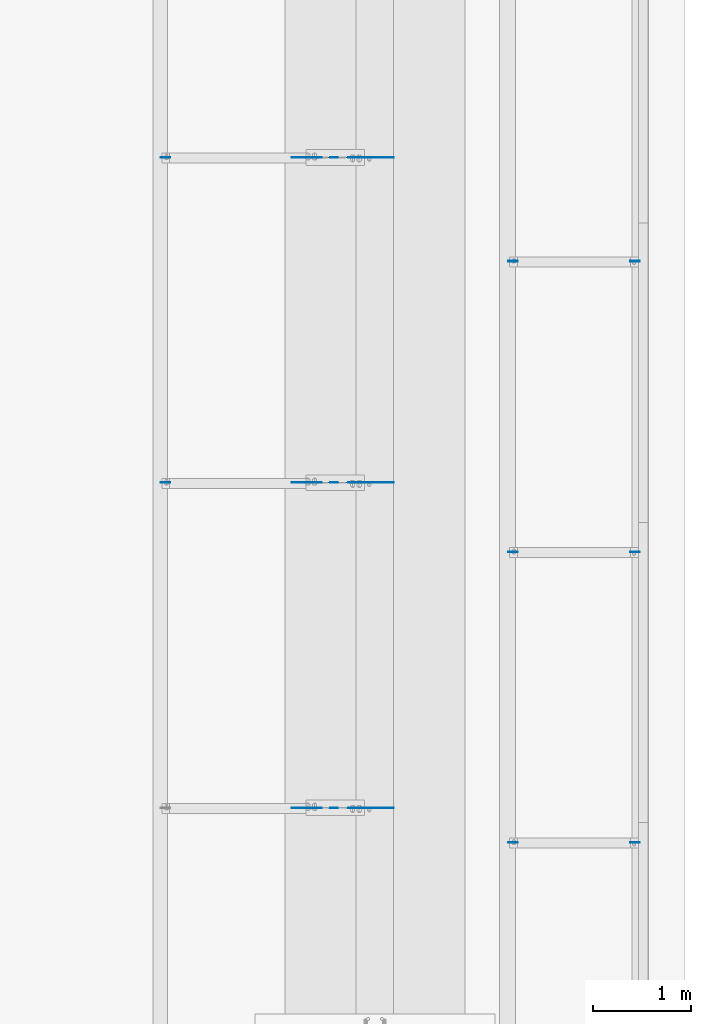
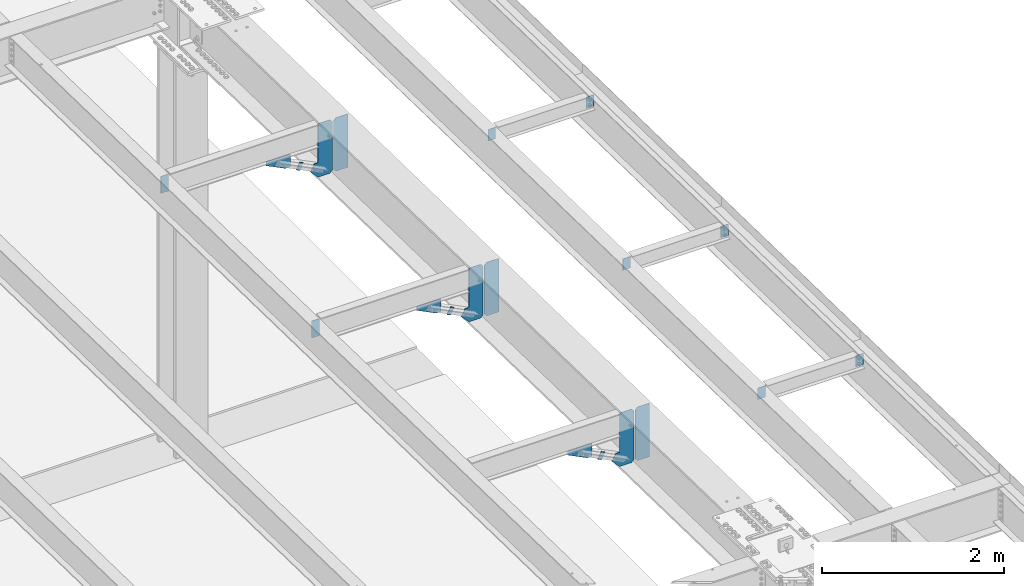
# One storey, part 1573 of 1763: 20 plates, 10 elements without a shape of their own.
"""IFC2X3 building model written with IfcOpenShell, lengths in millimetres."""

from ifc_helpers import new_model, si_unit, frame, origin_with_axes, place, context, subcontext, project, spatial, faceted_brep, material, type_object, element, aggregate, save


model = new_model("IFC2X3")

# Units and contexts
model_context = context("Model", 3, precision=1e-05, world=origin_with_axes())
body_context = subcontext(model_context, "Body", "Model", "MODEL_VIEW")
ifc_project = project(units=[si_unit("LENGTHUNIT", "METRE", prefix="MILLI"), si_unit("AREAUNIT", "SQUARE_METRE"), si_unit("VOLUMEUNIT", "CUBIC_METRE"), si_unit("MASSUNIT", "GRAM", prefix="KILO"), si_unit("TIMEUNIT", "SECOND"), si_unit("PLANEANGLEUNIT", "RADIAN"), si_unit("SOLIDANGLEUNIT", "STERADIAN"), si_unit("THERMODYNAMICTEMPERATUREUNIT", "DEGREE_CELSIUS"), si_unit("LUMINOUSINTENSITYUNIT", "LUMEN")], contexts=[model_context])

# Site, building, storey
site_placement = place(None, origin_with_axes())
site = spatial("IfcSite", under=ifc_project, at=site_placement, CompositionType="ELEMENT")
building_placement = place(site_placement, origin_with_axes())
building = spatial("IfcBuilding", under=site, at=building_placement, Name="Undefined", CompositionType="ELEMENT")
storey_placement = place(building_placement, origin_with_axes())
storey = spatial("IfcBuildingStorey", under=building, at=storey_placement, Name="Undefined", CompositionType="ELEMENT", Elevation=0.0)

# Assembly, plate
assembly_1_placement = place(storey_placement, origin_with_axes())
assembly_1 = element("IfcElementAssembly", 1, at=assembly_1_placement, inside=storey, Name="BEAM", AssemblyPlace="NOTDEFINED", PredefinedType="RIGID_FRAME")
ifc_material = material(Name="STEEL/A36")
plate_type_1 = type_object("IfcPlateType", PredefinedType="NOTDEFINED")
plate_1_placement = place(assembly_1_placement, frame((-24403.116526652, 10388.5999999862, 11216.3131961904), z_axis=(-0.894427191199916, 0.0, 0.447213595099958), x_axis=(-0.447213595099945, 0.0, -0.894427191199922)))
plate_1 = element("IfcPlate", 2, at=plate_1_placement, type_object=plate_type_1, material=ifc_material, Name="PLATE", context=body_context, shape_type="Brep", body=[
    faceted_brep([(1.81898940354586e-12, -3.17500000000291, 0.0), (0.0, -3.17500000000291, 50.7999992370605), (0.0, 3.17500000000291, 50.7999992370605), (-1.81898940354586e-12, 3.17499999997381, 0.0), (101.599998474121, -3.17500000000291, 50.7999992370605), (101.599998474121, 3.17500000000291, 50.7999992370605), (101.599990844785, -3.17499999999927, -1.81898940354586e-11), (101.599990844785, 3.17499999999927, -1.81898940354586e-11)], [[[0, 1, 2, 3]], [[1, 4, 5, 2]], [[4, 6, 7, 5]], [[6, 0, 3, 7]], [[5, 7, 3, 2]], [[6, 4, 1, 0]]]),
])
aggregate(assembly_1, [plate_1])

assembly_2_placement = place(storey_placement, origin_with_axes())
assembly_2 = element("IfcElementAssembly", 3, at=assembly_2_placement, inside=storey, Name="BEAM", AssemblyPlace="NOTDEFINED", PredefinedType="RIGID_FRAME")
plate_2_placement = place(assembly_2_placement, frame((-24403.116526652, 7080.25002965337, 11285.4981443707), z_axis=(-0.894427191199916, 0.0, 0.447213595099958), x_axis=(-0.447213595099945, 0.0, -0.894427191199922)))
plate_2 = element("IfcPlate", 4, at=plate_2_placement, type_object=plate_type_1, material=ifc_material, Name="PLATE", context=body_context, shape_type="Brep", body=[
    faceted_brep([(1.81898940354586e-12, -3.17500000000291, 0.0), (0.0, -3.17500000000291, 50.7999992370605), (0.0, 3.17500000000291, 50.7999992370605), (-1.81898940354586e-12, 3.17499999997381, 0.0), (101.599998474121, -3.17500000000291, 50.7999992370605), (101.599998474121, 3.17500000000291, 50.7999992370605), (101.599990844785, -3.17499999999927, -1.81898940354586e-11), (101.599990844785, 3.17499999999927, -1.81898940354586e-11)], [[[0, 1, 2, 3]], [[1, 4, 5, 2]], [[4, 6, 7, 5]], [[6, 0, 3, 7]], [[5, 7, 3, 2]], [[6, 4, 1, 0]]]),
])
aggregate(assembly_2, [plate_2])

assembly_3_placement = place(storey_placement, origin_with_axes())
assembly_3 = element("IfcElementAssembly", 5, at=assembly_3_placement, inside=storey, Name="BEAM", AssemblyPlace="NOTDEFINED", PredefinedType="RIGID_FRAME")
plate_3_placement = place(assembly_3_placement, frame((-24403.116526652, 3771.90002965336, 11354.6414165859), z_axis=(-0.894427191199916, 0.0, 0.447213595099958), x_axis=(-0.447213595099945, 0.0, -0.894427191199922)))
plate_3 = element("IfcPlate", 6, at=plate_3_placement, type_object=plate_type_1, material=ifc_material, Name="PLATE", context=body_context, shape_type="Brep", body=[
    faceted_brep([(1.81898940354586e-12, -3.17500000000291, 0.0), (0.0, -3.17500000000291, 50.7999992370605), (0.0, 3.17500000000291, 50.7999992370605), (-1.81898940354586e-12, 3.17499999997381, 0.0), (101.599998474121, -3.17500000000291, 50.7999992370605), (101.599998474121, 3.17500000000291, 50.7999992370605), (101.599990844785, -3.17499999999927, -1.81898940354586e-11), (101.599990844785, 3.17499999999927, -1.81898940354586e-11)], [[[0, 1, 2, 3]], [[1, 4, 5, 2]], [[4, 6, 7, 5]], [[6, 0, 3, 7]], [[5, 7, 3, 2]], [[6, 4, 1, 0]]]),
])
aggregate(assembly_3, [plate_3])

# Assembly, plates
assembly_4_placement = place(storey_placement, origin_with_axes())
assembly_4 = element("IfcElementAssembly", 7, at=assembly_4_placement, inside=storey, Name="BEAM", AssemblyPlace="NOTDEFINED", PredefinedType="RIGID_FRAME")
plate_type_2 = type_object("IfcPlateType", PredefinedType="NOTDEFINED")
plate_4_placement = place(assembly_4_placement, frame((-26208.2685236983, 10388.5999999996, 11662.8038399651), z_axis=(1.0, 0.0, 0.0), x_axis=(0.0, 0.0, -1.0)))
plate_4 = element("IfcPlate", 8, at=plate_4_placement, type_object=plate_type_2, material=ifc_material, Name="PLATE", context=body_context, shape_type="Brep", body=[
    faceted_brep([(1.81898940354586e-12, -3.17500000000291, 0.0), (0.0, -3.17499999999927, 96.8375015258789), (0.0, 3.17499999999927, 96.8375015258789), (-1.81898940354586e-12, 3.17499999997381, 0.0), (228.600006103516, -3.17499999999927, 96.8375015258789), (228.600006103516, 3.17499999999927, 96.8375015258789), (228.600006103516, -3.17500000001019, -7.27595761418343e-12), (228.600006103516, 3.17499999999563, -7.27595761418343e-12)], [[[0, 1, 2, 3]], [[1, 4, 5, 2]], [[4, 6, 7, 5]], [[6, 0, 3, 7]], [[5, 7, 3, 2]], [[6, 4, 1, 0]]]),
])
plate_5_placement = place(assembly_4_placement, frame((-26208.2685236983, 7080.25002966674, 11731.9887881477), z_axis=(1.0, 0.0, 0.0), x_axis=(0.0, 0.0, -1.0)))
plate_5 = element("IfcPlate", 9, at=plate_5_placement, type_object=plate_type_2, material=ifc_material, Name="PLATE", context=body_context, shape_type="Brep", body=[
    faceted_brep([(1.81898940354586e-12, -3.17500000000291, 0.0), (0.0, -3.17499999999927, 96.8375015258789), (0.0, 3.17499999999927, 96.8375015258789), (-1.81898940354586e-12, 3.17499999997381, 0.0), (228.600006103516, -3.17499999999927, 96.8375015258789), (228.600006103516, 3.17499999999927, 96.8375015258789), (228.600006103516, -3.17500000001019, -7.27595761418343e-12), (228.600006103516, 3.17499999999563, -7.27595761418343e-12)], [[[0, 1, 2, 3]], [[1, 4, 5, 2]], [[4, 6, 7, 5]], [[6, 0, 3, 7]], [[5, 7, 3, 2]], [[6, 4, 1, 0]]]),
])
aggregate(assembly_4, [plate_4, plate_5])

# Assembly, plate
assembly_5_placement = place(storey_placement, origin_with_axes())
assembly_5 = element("IfcElementAssembly", 10, at=assembly_5_placement, inside=storey, Name="BEAM", AssemblyPlace="NOTDEFINED", PredefinedType="RIGID_FRAME")
plate_6_placement = place(assembly_5_placement, frame((-21333.8497736983, 3419.31585699358, 11814.8365638702), z_axis=(-1.0, 0.0, 0.0), x_axis=(0.0, 0.0, -1.0)))
plate_6 = element("IfcPlate", 11, at=plate_6_placement, type_object=plate_type_2, material=ifc_material, Name="PLATE", context=body_context, shape_type="Brep", body=[
    faceted_brep([(1.81898940354586e-12, -3.17500000000291, 0.0), (0.0, -3.17499999999927, 96.8375015258789), (0.0, 3.17499999999927, 96.8375015258789), (-1.81898940354586e-12, 3.17499999997381, 0.0), (152.399993896484, -3.17499999999927, 96.8375015258789), (152.399993896484, 3.17499999999927, 96.8375015258789), (152.399993896484, -3.17500000000291, 0.0), (152.399993896484, 3.17500000000291, 0.0)], [[[0, 1, 2, 3]], [[1, 4, 5, 2]], [[4, 6, 7, 5]], [[6, 0, 3, 7]], [[5, 7, 3, 2]], [[6, 4, 1, 0]]]),
])

assembly_6_placement = place(storey_placement, origin_with_axes())
assembly_6 = element("IfcElementAssembly", 12, at=assembly_6_placement, inside=storey, Name="BEAM", AssemblyPlace="NOTDEFINED", PredefinedType="RIGID_FRAME")
plate_7_placement = place(assembly_6_placement, frame((-22673.6997736983, 3419.31585699359, 11814.8365638702), z_axis=(1.0, 0.0, 0.0), x_axis=(0.0, 0.0, -1.0)))
plate_7 = element("IfcPlate", 13, at=plate_7_placement, type_object=plate_type_2, material=ifc_material, Name="PLATE", context=body_context, shape_type="Brep", body=[
    faceted_brep([(1.81898940354586e-12, -3.17500000000291, 0.0), (0.0, -3.17499999999927, 96.8375015258789), (0.0, 3.17499999999927, 96.8375015258789), (-1.81898940354586e-12, 3.17499999997381, 0.0), (152.399993896484, -3.17499999999927, 96.8375015258789), (152.399993896484, 3.17499999999927, 96.8375015258789), (152.399993896484, -3.17500000000291, 0.0), (152.399993896484, 3.17500000000291, 0.0)], [[[0, 1, 2, 3]], [[1, 4, 5, 2]], [[4, 6, 7, 5]], [[6, 0, 3, 7]], [[5, 7, 3, 2]], [[6, 4, 1, 0]]]),
])

# Plate
plate_8_placement = place(assembly_5_placement, frame((-21333.8497736983, 6375.87789922992, 11753.0269053336), z_axis=(-1.0, 0.0, 0.0), x_axis=(0.0, 0.0, -1.0)))
plate_8 = element("IfcPlate", 14, at=plate_8_placement, type_object=plate_type_2, material=ifc_material, Name="PLATE", context=body_context, shape_type="Brep", body=[
    faceted_brep([(1.81898940354586e-12, -3.17500000000291, 0.0), (0.0, -3.17499999999927, 96.8375015258789), (0.0, 3.17499999999927, 96.8375015258789), (-1.81898940354586e-12, 3.17499999997381, 0.0), (152.399993896484, -3.17499999999927, 96.8375015258789), (152.399993896484, 3.17499999999927, 96.8375015258789), (152.399993896484, -3.17500000000291, 0.0), (152.399993896484, 3.17500000000291, 0.0)], [[[0, 1, 2, 3]], [[1, 4, 5, 2]], [[4, 6, 7, 5]], [[6, 0, 3, 7]], [[5, 7, 3, 2]], [[6, 4, 1, 0]]]),
])

plate_9_placement = place(assembly_6_placement, frame((-22673.6997736983, 6375.87789922992, 11753.0269053336), z_axis=(1.0, 0.0, 0.0), x_axis=(0.0, 0.0, -1.0)))
plate_9 = element("IfcPlate", 15, at=plate_9_placement, type_object=plate_type_2, material=ifc_material, Name="PLATE", context=body_context, shape_type="Brep", body=[
    faceted_brep([(1.81898940354586e-12, -3.17500000000291, 0.0), (0.0, -3.17499999999927, 96.8375015258789), (0.0, 3.17499999999927, 96.8375015258789), (-1.81898940354586e-12, 3.17499999997381, 0.0), (152.399993896484, -3.17499999999927, 96.8375015258789), (152.399993896484, 3.17499999999927, 96.8375015258789), (152.399993896484, -3.17500000000291, 0.0), (152.399993896484, 3.17500000000291, 0.0)], [[[0, 1, 2, 3]], [[1, 4, 5, 2]], [[4, 6, 7, 5]], [[6, 0, 3, 7]], [[5, 7, 3, 2]], [[6, 4, 1, 0]]]),
])

plate_10_placement = place(assembly_5_placement, frame((-21333.8497736983, 9332.43612676899, 11691.2173265468), z_axis=(-1.0, 0.0, 0.0), x_axis=(0.0, 0.0, -1.0)))
plate_10 = element("IfcPlate", 16, at=plate_10_placement, type_object=plate_type_2, material=ifc_material, Name="PLATE", context=body_context, shape_type="Brep", body=[
    faceted_brep([(1.81898940354586e-12, -3.17500000000291, 0.0), (0.0, -3.17499999999927, 96.8375015258789), (0.0, 3.17499999999927, 96.8375015258789), (-1.81898940354586e-12, 3.17499999997381, 0.0), (152.399993896484, -3.17499999999927, 96.8375015258789), (152.399993896484, 3.17499999999927, 96.8375015258789), (152.399993896484, -3.17500000000291, 0.0), (152.399993896484, 3.17500000000291, 0.0)], [[[0, 1, 2, 3]], [[1, 4, 5, 2]], [[4, 6, 7, 5]], [[6, 0, 3, 7]], [[5, 7, 3, 2]], [[6, 4, 1, 0]]]),
])

aggregate(assembly_5, [plate_6, plate_8, plate_10])

plate_11_placement = place(assembly_6_placement, frame((-22673.6997736983, 9332.43612676899, 11691.2173265468), z_axis=(1.0, 0.0, 0.0), x_axis=(0.0, 0.0, -1.0)))
plate_11 = element("IfcPlate", 17, at=plate_11_placement, type_object=plate_type_2, material=ifc_material, Name="PLATE", context=body_context, shape_type="Brep", body=[
    faceted_brep([(1.81898940354586e-12, -3.17500000000291, 0.0), (0.0, -3.17499999999927, 96.8375015258789), (0.0, 3.17499999999927, 96.8375015258789), (-1.81898940354586e-12, 3.17499999997381, 0.0), (152.399993896484, -3.17499999999927, 96.8375015258789), (152.399993896484, 3.17499999999927, 96.8375015258789), (152.399993896484, -3.17500000000291, 0.0), (152.399993896484, 3.17500000000291, 0.0)], [[[0, 1, 2, 3]], [[1, 4, 5, 2]], [[4, 6, 7, 5]], [[6, 0, 3, 7]], [[5, 7, 3, 2]], [[6, 4, 1, 0]]]),
])

aggregate(assembly_6, [plate_7, plate_9, plate_11])

# Assembly, plates
assembly_7_placement = place(storey_placement, origin_with_axes())
assembly_7 = element("IfcElementAssembly", 18, at=assembly_7_placement, inside=storey, Name="BEAM", AssemblyPlace="NOTDEFINED", PredefinedType="RIGID_FRAME")
plate_type_3 = type_object("IfcPlateType", PredefinedType="NOTDEFINED")
plate_12_placement = place(assembly_7_placement, frame((-24019.8997736984, 10388.5999999511, 10955.1476707848), z_axis=(0.0, 0.0, 1.0), x_axis=(1.0, 0.0, 0.0)))
plate_12 = element("IfcPlate", 19, at=plate_12_placement, type_object=plate_type_3, material=ifc_material, Name="PLATE", context=body_context, shape_type="Brep", body=[
    faceted_brep([(0.0, -3.17500000000291, 31.75), (0.0, -3.17499999999927, 685.224731445312), (0.0, 3.17499999999927, 685.224731445312), (0.0, 3.17500000000291, 31.75), (31.75, -3.17499999999927, 716.974731445312), (31.75, 3.17499999999927, 716.974731445312), (181.274993896484, -3.17499999999927, 716.974731445312), (181.274993896484, 3.17499999999927, 716.974731445312), (181.274993896484, -3.17499999999927, 0.0), (181.274993896484, 3.17499999999927, 0.0), (31.7499999999036, -3.17499999997381, 9.42916855706244e-11), (31.7499999998854, 3.17500000000291, 9.42916855706244e-11)], [[[0, 1, 2, 3]], [[1, 4, 5, 2]], [[4, 6, 7, 5]], [[6, 8, 9, 7]], [[8, 10, 11, 9]], [[10, 0, 3, 11]], [[5, 7, 9, 11, 3, 2]], [[10, 8, 6, 4, 1, 0]]]),
])
plate_13_placement = place(assembly_7_placement, frame((-24019.8997736984, 7080.25002961824, 11024.3326189651), z_axis=(0.0, 0.0, 1.0), x_axis=(1.0, 0.0, 0.0)))
plate_13 = element("IfcPlate", 20, at=plate_13_placement, type_object=plate_type_3, material=ifc_material, Name="PLATE", context=body_context, shape_type="Brep", body=[
    faceted_brep([(0.0, -3.17500000000291, 31.75), (0.0, -3.17499999999927, 685.224731445312), (0.0, 3.17499999999927, 685.224731445312), (0.0, 3.17500000000291, 31.75), (31.75, -3.17499999999927, 716.974731445312), (31.75, 3.17499999999927, 716.974731445312), (181.274993896484, -3.17499999999927, 716.974731445312), (181.274993896484, 3.17499999999927, 716.974731445312), (181.274993896484, -3.17499999999927, 0.0), (181.274993896484, 3.17499999999927, 0.0), (31.7499999999036, -3.17499999997381, 9.42916855706244e-11), (31.7499999998854, 3.17500000000291, 9.42916855706244e-11)], [[[0, 1, 2, 3]], [[1, 4, 5, 2]], [[4, 6, 7, 5]], [[6, 8, 9, 7]], [[8, 10, 11, 9]], [[10, 0, 3, 11]], [[5, 7, 9, 11, 3, 2]], [[10, 8, 6, 4, 1, 0]]]),
])
plate_14_placement = place(assembly_7_placement, frame((-24019.8997736984, 3771.90002956786, 11093.4758911803), z_axis=(0.0, 0.0, 1.0), x_axis=(1.0, 0.0, 0.0)))
plate_14 = element("IfcPlate", 21, at=plate_14_placement, type_object=plate_type_3, material=ifc_material, Name="PLATE", context=body_context, shape_type="Brep", body=[
    faceted_brep([(0.0, -3.17500000000291, 31.75), (0.0, -3.17499999999927, 685.224731445312), (0.0, 3.17499999999927, 685.224731445312), (0.0, 3.17500000000291, 31.75), (31.75, -3.17499999999927, 716.974731445312), (31.75, 3.17499999999927, 716.974731445312), (181.274993896484, -3.17499999999927, 716.974731445312), (181.274993896484, 3.17499999999927, 716.974731445312), (181.274993896484, -3.17499999999927, 0.0), (181.274993896484, 3.17499999999927, 0.0), (31.7499999999036, -3.17499999997381, 9.42916855706244e-11), (31.7499999998854, 3.17500000000291, 9.42916855706244e-11)], [[[0, 1, 2, 3]], [[1, 4, 5, 2]], [[4, 6, 7, 5]], [[6, 8, 9, 7]], [[8, 10, 11, 9]], [[10, 0, 3, 11]], [[5, 7, 9, 11, 3, 2]], [[10, 8, 6, 4, 1, 0]]]),
])
plate_type_4 = type_object("IfcPlateType", PredefinedType="NOTDEFINED")
plate_15_placement = place(assembly_7_placement, frame((-24035.7747736984, 10388.5999999511, 10955.1476707848), z_axis=(0.0, 0.0, 1.0), x_axis=(-1.0, 0.0, 0.0)))
plate_15 = element("IfcPlate", 22, at=plate_15_placement, type_object=plate_type_4, material=ifc_material, Name="PLATE", context=body_context, shape_type="Brep", body=[
    faceted_brep([(0.0, -3.17500000000291, 31.75), (0.0, -3.17499999999927, 685.224792480469), (0.0, 3.17499999999927, 685.224792480469), (0.0, 3.17500000000291, 31.75), (31.75, -3.17499999999927, 716.974792480469), (31.75, 3.17499999999927, 716.974792480469), (182.5625, -3.17499999999927, 716.974792480469), (182.5625, 3.17499999999927, 716.974792480469), (182.5625, -3.17499999999927, 192.797760009766), (182.5625, 3.17499999999927, 192.797760009766), (230.606231689453, -3.17499999999927, 192.797760009766), (230.606231689453, 3.17499999999927, 192.797760009766), (276.043121337891, -3.17499999999927, 101.923965454102), (276.043121337891, 3.17499999999927, 101.923965454102), (182.5625, -3.17500000000291, 0.0), (182.5625, 3.17500000000291, 0.0), (31.7499999999036, -3.17499999997381, 9.42916855706244e-11), (31.7499999998854, 3.17500000000291, 9.42916855706244e-11)], [[[0, 1, 2, 3]], [[1, 4, 5, 2]], [[4, 6, 7, 5]], [[6, 8, 9, 7]], [[8, 10, 11, 9]], [[10, 12, 13, 11]], [[12, 14, 15, 13]], [[14, 16, 17, 15]], [[16, 0, 3, 17]], [[5, 7, 9, 11, 13, 15, 17, 3, 2]], [[16, 14, 12, 10, 8, 6, 4, 1, 0]]]),
])
plate_16_placement = place(assembly_7_placement, frame((-24035.7747736984, 7080.25002961824, 11024.3326189651), z_axis=(0.0, 0.0, 1.0), x_axis=(-1.0, 0.0, 0.0)))
plate_16 = element("IfcPlate", 23, at=plate_16_placement, type_object=plate_type_4, material=ifc_material, Name="PLATE", context=body_context, shape_type="Brep", body=[
    faceted_brep([(0.0, -3.17500000000291, 31.75), (0.0, -3.17499999999927, 685.224792480469), (0.0, 3.17499999999927, 685.224792480469), (0.0, 3.17500000000291, 31.75), (31.75, -3.17499999999927, 716.974792480469), (31.75, 3.17499999999927, 716.974792480469), (182.5625, -3.17499999999927, 716.974792480469), (182.5625, 3.17499999999927, 716.974792480469), (182.5625, -3.17499999999927, 192.797760009766), (182.5625, 3.17499999999927, 192.797760009766), (230.606231689453, -3.17499999999927, 192.797760009766), (230.606231689453, 3.17499999999927, 192.797760009766), (276.043121337891, -3.17499999999927, 101.923965454102), (276.043121337891, 3.17499999999927, 101.923965454102), (182.5625, -3.17500000000291, 0.0), (182.5625, 3.17500000000291, 0.0), (31.7499999999036, -3.17499999997381, 9.42916855706244e-11), (31.7499999998854, 3.17500000000291, 9.42916855706244e-11)], [[[0, 1, 2, 3]], [[1, 4, 5, 2]], [[4, 6, 7, 5]], [[6, 8, 9, 7]], [[8, 10, 11, 9]], [[10, 12, 13, 11]], [[12, 14, 15, 13]], [[14, 16, 17, 15]], [[16, 0, 3, 17]], [[5, 7, 9, 11, 13, 15, 17, 3, 2]], [[16, 14, 12, 10, 8, 6, 4, 1, 0]]]),
])
plate_17_placement = place(assembly_7_placement, frame((-24035.7747736984, 3771.90002961824, 11093.4758911803), z_axis=(0.0, 0.0, 1.0), x_axis=(-1.0, 0.0, 0.0)))
plate_17 = element("IfcPlate", 24, at=plate_17_placement, type_object=plate_type_4, material=ifc_material, Name="PLATE", context=body_context, shape_type="Brep", body=[
    faceted_brep([(0.0, -3.17500000000291, 31.75), (0.0, -3.17499999999927, 685.224792480469), (0.0, 3.17499999999927, 685.224792480469), (0.0, 3.17500000000291, 31.75), (31.75, -3.17499999999927, 716.974792480469), (31.75, 3.17499999999927, 716.974792480469), (182.5625, -3.17499999999927, 716.974792480469), (182.5625, 3.17499999999927, 716.974792480469), (182.5625, -3.17499999999927, 192.797760009766), (182.5625, 3.17499999999927, 192.797760009766), (230.606231689453, -3.17499999999927, 192.797760009766), (230.606231689453, 3.17499999999927, 192.797760009766), (276.043121337891, -3.17499999999927, 101.923965454102), (276.043121337891, 3.17499999999927, 101.923965454102), (182.5625, -3.17500000000291, 0.0), (182.5625, 3.17500000000291, 0.0), (31.7499999999036, -3.17499999997381, 9.42916855706244e-11), (31.7499999998854, 3.17500000000291, 9.42916855706244e-11)], [[[0, 1, 2, 3]], [[1, 4, 5, 2]], [[4, 6, 7, 5]], [[6, 8, 9, 7]], [[8, 10, 11, 9]], [[10, 12, 13, 11]], [[12, 14, 15, 13]], [[14, 16, 17, 15]], [[16, 0, 3, 17]], [[5, 7, 9, 11, 13, 15, 17, 3, 2]], [[16, 14, 12, 10, 8, 6, 4, 1, 0]]]),
])
aggregate(assembly_7, [plate_12, plate_15, plate_13, plate_16, plate_14, plate_17])

# Assembly, plate
assembly_8_placement = place(storey_placement, origin_with_axes())
assembly_8 = element("IfcElementAssembly", 25, at=assembly_8_placement, inside=storey, Name="BEAM", AssemblyPlace="NOTDEFINED", PredefinedType="RIGID_FRAME")
plate_type_5 = type_object("IfcPlateType", PredefinedType="NOTDEFINED")
plate_18_placement = place(assembly_8_placement, frame((-24569.5117650555, 10388.5999999993, 11389.7537944922), z_axis=(-1.0, 0.0, 0.0), x_axis=(0.0, 0.0, -1.0)))
plate_18 = element("IfcPlate", 26, at=plate_18_placement, type_object=plate_type_5, material=ifc_material, Name="PLATE", context=body_context, shape_type="Brep", body=[
    faceted_brep([(1.81898940354586e-12, -3.17500000000291, 0.0), (0.0, -3.17499999999927, 306.070465087891), (0.0, 3.17499999999927, 306.070465087891), (-1.81898940354586e-12, 3.17499999997381, 0.0), (50.7999992370605, -3.17499999999927, 306.070465087891), (50.7999992370605, 3.17499999999927, 306.070465087891), (172.922760009766, -3.17499999999927, 61.8249359130859), (172.922760009766, 3.17499999999927, 61.8249359130859), (172.922760009766, -3.17499999999927, 0.0), (172.922760009766, 3.17499999999927, 0.0)], [[[0, 1, 2, 3]], [[1, 4, 5, 2]], [[4, 6, 7, 5]], [[6, 8, 9, 7]], [[8, 0, 3, 9]], [[5, 7, 9, 3, 2]], [[8, 6, 4, 1, 0]]]),
])
aggregate(assembly_8, [plate_18])

assembly_9_placement = place(storey_placement, origin_with_axes())
assembly_9 = element("IfcElementAssembly", 27, at=assembly_9_placement, inside=storey, Name="BEAM", AssemblyPlace="NOTDEFINED", PredefinedType="RIGID_FRAME")
plate_19_placement = place(assembly_9_placement, frame((-24569.5117650555, 7080.25002966651, 11458.9387426725), z_axis=(-1.0, 0.0, 0.0), x_axis=(0.0, 0.0, -1.0)))
plate_19 = element("IfcPlate", 28, at=plate_19_placement, type_object=plate_type_5, material=ifc_material, Name="PLATE", context=body_context, shape_type="Brep", body=[
    faceted_brep([(1.81898940354586e-12, -3.17500000000291, 0.0), (0.0, -3.17499999999927, 306.070465087891), (0.0, 3.17499999999927, 306.070465087891), (-1.81898940354586e-12, 3.17499999997381, 0.0), (50.7999992370605, -3.17499999999927, 306.070465087891), (50.7999992370605, 3.17499999999927, 306.070465087891), (172.922760009766, -3.17499999999927, 61.8249359130859), (172.922760009766, 3.17499999999927, 61.8249359130859), (172.922760009766, -3.17499999999927, 0.0), (172.922760009766, 3.17499999999927, 0.0)], [[[0, 1, 2, 3]], [[1, 4, 5, 2]], [[4, 6, 7, 5]], [[6, 8, 9, 7]], [[8, 0, 3, 9]], [[5, 7, 9, 3, 2]], [[8, 6, 4, 1, 0]]]),
])
aggregate(assembly_9, [plate_19])

assembly_10_placement = place(storey_placement, origin_with_axes())
assembly_10 = element("IfcElementAssembly", 29, at=assembly_10_placement, inside=storey, Name="BEAM", AssemblyPlace="NOTDEFINED", PredefinedType="RIGID_FRAME")
plate_20_placement = place(assembly_10_placement, frame((-24569.5117650555, 3771.90002966651, 11528.0820148877), z_axis=(-1.0, 0.0, 0.0), x_axis=(0.0, 0.0, -1.0)))
plate_20 = element("IfcPlate", 30, at=plate_20_placement, type_object=plate_type_5, material=ifc_material, Name="PLATE", context=body_context, shape_type="Brep", body=[
    faceted_brep([(1.81898940354586e-12, -3.17500000000291, 0.0), (0.0, -3.17499999999927, 306.070465087891), (0.0, 3.17499999999927, 306.070465087891), (-1.81898940354586e-12, 3.17499999997381, 0.0), (50.7999992370605, -3.17499999999927, 306.070465087891), (50.7999992370605, 3.17499999999927, 306.070465087891), (172.922760009766, -3.17499999999927, 61.8249359130859), (172.922760009766, 3.17499999999927, 61.8249359130859), (172.922760009766, -3.17499999999927, 0.0), (172.922760009766, 3.17499999999927, 0.0)], [[[0, 1, 2, 3]], [[1, 4, 5, 2]], [[4, 6, 7, 5]], [[6, 8, 9, 7]], [[8, 0, 3, 9]], [[5, 7, 9, 3, 2]], [[8, 6, 4, 1, 0]]]),
])
aggregate(assembly_10, [plate_20])

save(model, "model.ifc")
